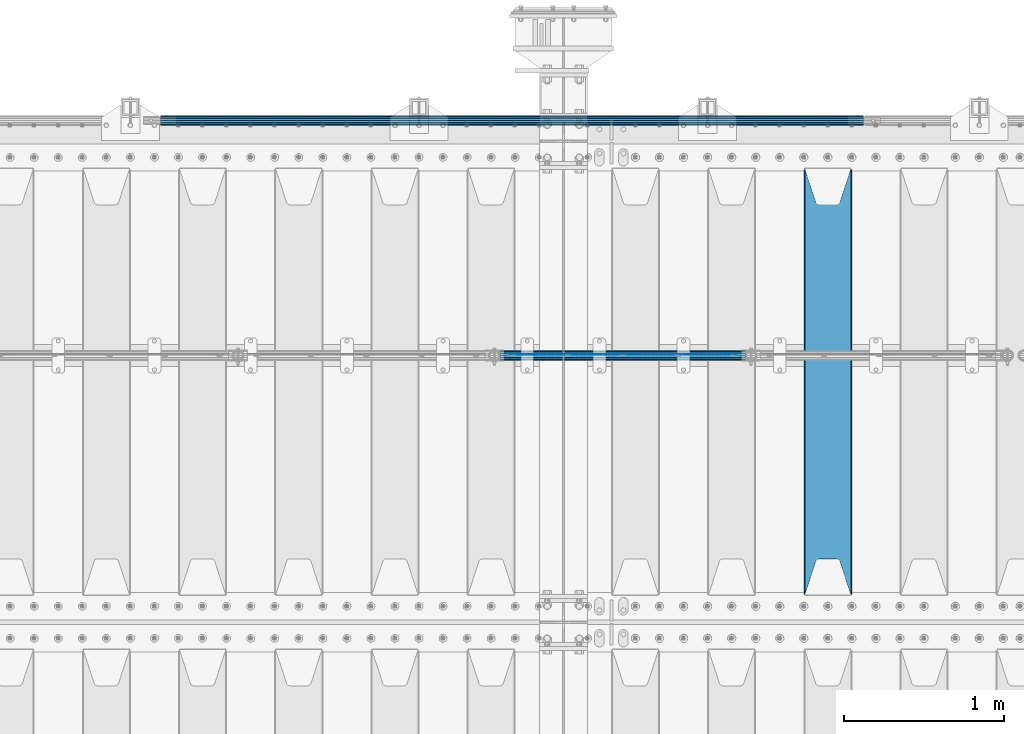
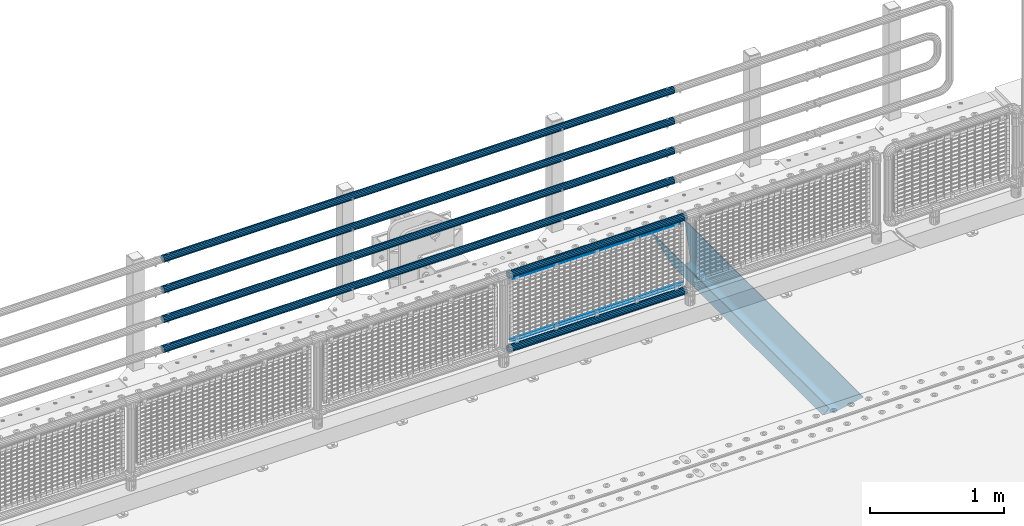
# One storey, part 128 of 247: 10 beams.
"""IFC2X3 building model written with IfcOpenShell, lengths in millimetres."""

from ifc_helpers import new_model, si_unit, frame, origin_with_axes, place, context, subcontext, project, spatial, faceted_brep, material, type_object, element, save


model = new_model("IFC2X3")

# Units and contexts
model_context = context("Model", 3, precision=1e-05, world=origin_with_axes())
body_context = subcontext(model_context, "Body", "Model", "MODEL_VIEW")
ifc_project = project(units=[si_unit("LENGTHUNIT", "METRE", prefix="MILLI"), si_unit("AREAUNIT", "SQUARE_METRE"), si_unit("VOLUMEUNIT", "CUBIC_METRE"), si_unit("MASSUNIT", "GRAM", prefix="KILO"), si_unit("TIMEUNIT", "SECOND"), si_unit("PLANEANGLEUNIT", "RADIAN"), si_unit("SOLIDANGLEUNIT", "STERADIAN"), si_unit("THERMODYNAMICTEMPERATUREUNIT", "DEGREE_CELSIUS"), si_unit("LUMINOUSINTENSITYUNIT", "LUMEN")], contexts=[model_context])

# Site, building, storey
site_placement = place(None, origin_with_axes())
site = spatial("IfcSite", under=ifc_project, at=site_placement, CompositionType="ELEMENT")
building_placement = place(site_placement, origin_with_axes())
building = spatial("IfcBuilding", under=site, at=building_placement, Name="Standard", CompositionType="ELEMENT")
storey_placement = place(building_placement, origin_with_axes())
storey = spatial("IfcBuildingStorey", under=building, at=storey_placement, Name="Undefined", CompositionType="ELEMENT", Elevation=0.0)

# Beams
ifc_material_1 = material(Name="STEEL/S355N")
beam_type_1 = type_object("IfcBeamType", PredefinedType="NOTDEFINED")
beam_1_placement = place(storey_placement, frame((13900.0, 6175.0, -115.0), z_axis=(0.0, 0.0, 1.0), x_axis=(0.0, 1.0, 0.0)))
element("IfcBeam", 1, at=beam_1_placement, inside=storey, type_object=beam_type_1, material=ifc_material_1, context=body_context, shape_type="Brep", body=[
    faceted_brep([(0.0, 150.0, 115.0), (0.0, 143.689999999999, 115.0), (2650.00000000297, 143.689999999999, 115.0), (2650.00000000297, 150.0, 115.0), (2650.00000000297, 142.059565218402, 110.0000000031), (2650.00000000297, 148.369565218403, 110.0000000031), (2441.90079219208, -80.1103600731112, -98.0992078077845), (2437.7588105432, -77.5672621345584, -102.241189456673), (2434.06523489746, -74.4080125315522, -105.934765102404), (2430.91086095089, -70.710272125576, -109.089139048974), (2428.37322971128, -66.5649389910068, -111.626770288588), (2426.51472138054, -62.0739139532889, -113.485278619323), (2425.38102192091, -57.3475956567672, -114.618978078955), (2424.99999999987, -52.5021667386536, -115.0), (2424.99999999987, 52.5021667386536, -115.0), (2425.38102192091, 57.3475956567672, -114.618978078955), (2426.51472138054, 62.0739139532889, -113.485278619323), (2428.37322971128, 66.5649389910068, -111.626770288588), (2430.91086095089, 70.710272125576, -109.089139048974), (2434.06523489746, 74.4080125315522, -105.934765102404), (2437.7588105432, 77.5672621345584, -102.241189456673), (2441.90079219208, 80.1103600731112, -98.0992078077846), (2446.38936140511, 81.9747917625791, -93.6106385947584), (2448.24948500409, 76.2713538057251, -91.7505149957729), (2444.62967112262, 74.76777986261, -95.3703288772456), (2441.28936334126, 72.7168944282894, -98.710636658607), (2438.31067330438, 70.1691124903846, -101.689326695487), (2435.76682334747, 67.1870637758839, -104.233176652398), (2433.72034654133, 63.8440531834895, -106.279653458539), (2432.22154950041, 60.222258798236, -107.778450499454), (2431.30727574265, 56.4107117849089, -108.692724257221), (2430.99999999987, 52.5031078186876, -109.0), (2430.99999999987, -52.5031078186876, -109.0), (2431.30727574265, -56.4107117849089, -108.692724257221), (2432.22154950041, -60.222258798236, -107.778450499454), (2433.72034654133, -63.8440531834895, -106.279653458539), (2435.76682334747, -67.1870637758839, -104.233176652398), (2438.31067330438, -70.1691124903846, -101.689326695487), (2441.28936334126, -72.7168944282894, -98.7106366586071), (2444.62967112262, -74.76777986261, -95.3703288772457), (2448.24948500409, -76.2713538057251, -91.7505149957729), (2650.00000000297, -142.059565218402, 110.0000000031), (2650.00000000297, -148.369565218403, 110.0000000031), (2446.38936140511, -81.9747917625791, -93.6106385947584), (2650.00000000297, -143.689999999999, 115.0), (2650.00000000297, -150.0, 115.0), (0.0, -143.689999999999, 115.0), (0.0, -150.0, 115.0), (0.0, -148.369565218261, 110.000000002663), (203.610638597422, -81.9747917625791, -93.6106385947584), (208.099207810448, -80.1103600731112, -98.0992078077845), (212.241189459336, -77.5672621345584, -102.241189456673), (215.934765105068, -74.4080125315522, -105.934765102404), (219.089139051637, -70.710272125576, -109.089139048974), (221.626770291251, -66.5649389910068, -111.626770288588), (223.485278621985, -62.0739139532889, -113.485278619323), (224.618978081617, -57.3475956567672, -114.618978078955), (225.000000002663, -52.5021667386536, -115.0), (225.000000002663, 52.5021667386536, -115.0), (224.618978081617, 57.3475956567672, -114.618978078955), (223.485278621985, 62.0739139532889, -113.485278619323), (221.626770291251, 66.5649389910068, -111.626770288588), (219.089139051637, 70.710272125576, -109.089139048974), (215.934765105068, 74.4080125315522, -105.934765102404), (212.241189459336, 77.5672621345584, -102.241189456673), (208.099207810448, 80.1103600731112, -98.0992078077846), (203.610638597422, 81.9747917625791, -93.6106385947584), (0.0, 148.369565218261, 110.000000002663), (0.0, 142.05956521826, 110.000000002663), (201.750514998436, 76.2713538057251, -91.7505149957729), (205.370328879908, 74.76777986261, -95.3703288772456), (208.710636661271, 72.7168944282894, -98.710636658607), (211.68932669815, 70.1691124903846, -101.689326695487), (214.233176655061, 67.1870637758839, -104.233176652398), (216.279653461202, 63.8440531834895, -106.279653458539), (217.778450502117, 60.222258798236, -107.778450499454), (218.692724259885, 56.4107117849089, -108.692724257221), (219.000000002663, 52.5031078186876, -109.0), (219.000000002663, -52.5031078186876, -109.0), (218.692724259885, -56.4107117849089, -108.692724257221), (217.778450502117, -60.222258798236, -107.778450499454), (216.279653461202, -63.8440531834895, -106.279653458539), (214.233176655061, -67.1870637758839, -104.233176652398), (211.68932669815, -70.1691124903846, -101.689326695487), (208.710636661271, -72.7168944282894, -98.7106366586071), (205.370328879908, -74.76777986261, -95.3703288772457), (201.750514998436, -76.2713538057251, -91.7505149957729), (0.0, -142.05956521826, 110.000000002663)], [[[0, 1, 2, 3]], [[3, 2, 4, 5]], [[6, 7, 8, 9, 10, 11, 12, 13, 14, 15, 16, 17, 18, 19, 20, 21, 22, 5, 4, 23, 24, 25, 26, 27, 28, 29, 30, 31, 32, 33, 34, 35, 36, 37, 38, 39, 40, 41, 42, 43]], [[44, 45, 42, 41]], [[46, 47, 45, 44]], [[43, 42, 45, 47, 48, 49]], [[6, 43, 49, 50]], [[7, 6, 50, 51]], [[8, 7, 51, 52]], [[9, 8, 52, 53]], [[10, 9, 53, 54]], [[11, 10, 54, 55]], [[12, 11, 55, 56]], [[13, 12, 56, 57]], [[14, 13, 57, 58]], [[15, 14, 58, 59]], [[16, 15, 59, 60]], [[17, 16, 60, 61]], [[18, 17, 61, 62]], [[19, 18, 62, 63]], [[20, 19, 63, 64]], [[21, 20, 64, 65]], [[22, 21, 65, 66]], [[0, 3, 5, 22, 66, 67]], [[1, 0, 67, 68]], [[23, 4, 2, 1, 68, 69]], [[24, 23, 69, 70]], [[25, 24, 70, 71]], [[26, 25, 71, 72]], [[27, 26, 72, 73]], [[28, 27, 73, 74]], [[29, 28, 74, 75]], [[30, 29, 75, 76]], [[31, 30, 76, 77]], [[32, 31, 77, 78]], [[33, 32, 78, 79]], [[34, 33, 79, 80]], [[35, 34, 80, 81]], [[36, 35, 81, 82]], [[37, 36, 82, 83]], [[38, 37, 83, 84]], [[39, 38, 84, 85]], [[40, 39, 85, 86]], [[46, 44, 41, 40, 86, 87]], [[47, 46, 87, 48]], [[86, 85, 84, 83, 82, 81, 80, 79, 78, 77, 76, 75, 74, 73, 72, 71, 70, 69, 68, 67, 66, 65, 64, 63, 62, 61, 60, 59, 58, 57, 56, 55, 54, 53, 52, 51, 50, 49, 48, 87]]]),
])
ifc_material_2 = material()
beam_type_2 = type_object("IfcBeamType", PredefinedType="NOTDEFINED")
beam_2_placement = place(storey_placement, frame((14121.9999999999, 9129.8500000002, 149.849999999725), z_axis=(0.0, 0.0, -1.0), x_axis=(-1.0, 0.0, 0.0)))
element("IfcBeam", 2, at=beam_2_placement, inside=storey, type_object=beam_type_2, material=ifc_material_2, context=body_context, shape_type="Brep", body=[
    faceted_brep([(0.0, -26.5499999999993, 0.0), (0.0, -24.5290015881747, 10.1602451292931), (4384.0, -24.5290015881747, 10.1602451292931), (4384.0, -26.5499999999993, 0.0), (0.0, -18.7736850405036, 18.7736850405028), (4384.0, -18.7736850405036, 18.7736850405028), (0.0, -10.1602451292929, 24.5290015881747), (4384.0, -10.1602451292929, 24.5290015881747), (0.0, 0.0, 26.55), (4384.0, 0.0, 26.55), (0.0, 10.1602451292929, 24.5290015881747), (4384.0, 10.1602451292929, 24.5290015881747), (0.0, 18.7736850405036, 18.7736850405028), (4384.0, 18.7736850405036, 18.7736850405028), (0.0, 24.5290015881747, 10.1602451292931), (4384.0, 24.5290015881747, 10.1602451292931), (0.0, 26.5499999999993, 0.0), (4384.0, 26.5499999999993, 0.0), (0.0, 24.5290015881747, -10.1602451292931), (4384.0, 24.5290015881747, -10.1602451292931), (0.0, 18.7736850405036, -18.7736850405028), (4384.0, 18.7736850405036, -18.7736850405028), (0.0, 10.1602451292929, -24.5290015881747), (4384.0, 10.1602451292929, -24.5290015881747), (0.0, 0.0, -26.55), (4384.0, 0.0, -26.55), (0.0, -10.1602451292929, -24.5290015881747), (4384.0, -10.1602451292929, -24.5290015881747), (0.0, -18.7736850405036, -18.7736850405028), (4384.0, -18.7736850405036, -18.7736850405028), (0.0, -24.5290015881747, -10.1602451292931), (4384.0, -24.5290015881747, -10.1602451292931), (0.0, -30.1499999999996, 0.0), (0.0, -27.8549679052148, -11.5379054858076), (4384.0, -27.8549679052157, -11.5379054858075), (4384.0, -30.1499999999996, 0.0), (0.0, -21.3192694527743, -21.3192694527752), (4384.0, -21.3192694527752, -21.3192694527744), (0.0, -11.5379054858076, -27.8549679052157), (4384.0, -11.5379054858076, -27.8549679052153), (0.0, 0.0, -30.1499999999996), (4384.0, 0.0, -30.15), (0.0, 11.5379054858076, -27.8549679052157), (4384.0, 11.5379054858076, -27.8549679052153), (0.0, 21.3192694527743, -21.3192694527752), (4384.0, 21.3192694527752, -21.3192694527744), (0.0, 27.8549679052157, -11.5379054858076), (4384.0, 27.8549679052157, -11.5379054858074), (0.0, 30.1499999999996, 0.0), (4384.0, 30.1499999999996, 0.0), (0.0, 27.8549679052157, 11.5379054858076), (4384.0, 27.8549679052157, 11.5379054858075), (0.0, 21.3192694527743, 21.3192694527752), (4384.0, 21.3192694527752, 21.3192694527744), (0.0, 11.5379054858076, 27.8549679052157), (4384.0, 11.5379054858076, 27.8549679052153), (0.0, 0.0, 30.1499999999996), (4384.0, 0.0, 30.15), (0.0, -11.5379054858076, 27.8549679052157), (4384.0, -11.5379054858076, 27.8549679052153), (0.0, -21.3192694527743, 21.3192694527752), (4384.0, -21.3192694527752, 21.3192694527744), (0.0, -27.8549679052157, 11.5379054858076), (4384.0, -27.8549679052157, 11.5379054858075)], [[[0, 1, 2, 3]], [[1, 4, 5, 2]], [[4, 6, 7, 5]], [[6, 8, 9, 7]], [[8, 10, 11, 9]], [[10, 12, 13, 11]], [[12, 14, 15, 13]], [[14, 16, 17, 15]], [[16, 18, 19, 17]], [[18, 20, 21, 19]], [[20, 22, 23, 21]], [[22, 24, 25, 23]], [[24, 26, 27, 25]], [[26, 28, 29, 27]], [[28, 30, 31, 29]], [[30, 0, 3, 31]], [[32, 33, 34, 35]], [[33, 36, 37, 34]], [[36, 38, 39, 37]], [[38, 40, 41, 39]], [[40, 42, 43, 41]], [[42, 44, 45, 43]], [[44, 46, 47, 45]], [[46, 48, 49, 47]], [[48, 50, 51, 49]], [[50, 52, 53, 51]], [[52, 54, 55, 53]], [[54, 56, 57, 55]], [[56, 58, 59, 57]], [[58, 60, 61, 59]], [[60, 62, 63, 61]], [[62, 32, 35, 63]], [[37, 39, 41, 43, 45, 47, 49, 51, 53, 55, 57, 59, 61, 63, 35, 34], [5, 7, 9, 11, 13, 15, 17, 19, 21, 23, 25, 27, 29, 31, 3, 2]], [[62, 60, 58, 56, 54, 52, 50, 48, 46, 44, 42, 40, 38, 36, 33, 32], [30, 28, 26, 24, 22, 20, 18, 16, 14, 12, 10, 8, 6, 4, 1, 0]]]),
])
beam_3_placement = place(storey_placement, frame((14121.9999999999, 9129.8500000002, 420.149999999728), z_axis=(0.0, 0.0, -1.0), x_axis=(-1.0, 0.0, 0.0)))
element("IfcBeam", 3, at=beam_3_placement, inside=storey, type_object=beam_type_2, material=ifc_material_2, context=body_context, shape_type="Brep", body=[
    faceted_brep([(0.0, -26.5499999999993, 0.0), (0.0, -24.5290015881747, 10.1602451292931), (4384.0, -24.5290015881747, 10.1602451292931), (4384.0, -26.5499999999993, 0.0), (0.0, -18.7736850405036, 18.7736850405028), (4384.0, -18.7736850405036, 18.7736850405028), (0.0, -10.1602451292929, 24.5290015881747), (4384.0, -10.1602451292929, 24.5290015881747), (0.0, 0.0, 26.55), (4384.0, 0.0, 26.55), (0.0, 10.1602451292929, 24.5290015881747), (4384.0, 10.1602451292929, 24.5290015881747), (0.0, 18.7736850405036, 18.7736850405028), (4384.0, 18.7736850405036, 18.7736850405028), (0.0, 24.5290015881747, 10.1602451292931), (4384.0, 24.5290015881747, 10.1602451292931), (0.0, 26.5499999999993, 0.0), (4384.0, 26.5499999999993, 0.0), (0.0, 24.5290015881747, -10.1602451292931), (4384.0, 24.5290015881747, -10.1602451292931), (0.0, 18.7736850405036, -18.7736850405028), (4384.0, 18.7736850405036, -18.7736850405028), (0.0, 10.1602451292929, -24.5290015881747), (4384.0, 10.1602451292929, -24.5290015881747), (0.0, 0.0, -26.55), (4384.0, 0.0, -26.55), (0.0, -10.1602451292929, -24.5290015881747), (4384.0, -10.1602451292929, -24.5290015881747), (0.0, -18.7736850405036, -18.7736850405028), (4384.0, -18.7736850405036, -18.7736850405028), (0.0, -24.5290015881747, -10.1602451292931), (4384.0, -24.5290015881747, -10.1602451292931), (0.0, -30.1499999999996, 0.0), (0.0, -27.8549679052148, -11.5379054858076), (4384.0, -27.8549679052157, -11.5379054858075), (4384.0, -30.1499999999996, 0.0), (0.0, -21.3192694527743, -21.3192694527752), (4384.0, -21.3192694527752, -21.3192694527744), (0.0, -11.5379054858076, -27.8549679052157), (4384.0, -11.5379054858076, -27.8549679052153), (0.0, 0.0, -30.1499999999996), (4384.0, 0.0, -30.15), (0.0, 11.5379054858076, -27.8549679052157), (4384.0, 11.5379054858076, -27.8549679052153), (0.0, 21.3192694527743, -21.3192694527752), (4384.0, 21.3192694527752, -21.3192694527744), (0.0, 27.8549679052157, -11.5379054858076), (4384.0, 27.8549679052157, -11.5379054858074), (0.0, 30.1499999999996, 0.0), (4384.0, 30.1499999999996, 0.0), (0.0, 27.8549679052157, 11.5379054858076), (4384.0, 27.8549679052157, 11.5379054858075), (0.0, 21.3192694527743, 21.3192694527752), (4384.0, 21.3192694527752, 21.3192694527744), (0.0, 11.5379054858076, 27.8549679052157), (4384.0, 11.5379054858076, 27.8549679052153), (0.0, 0.0, 30.1499999999996), (4384.0, 0.0, 30.15), (0.0, -11.5379054858076, 27.8549679052157), (4384.0, -11.5379054858076, 27.8549679052153), (0.0, -21.3192694527743, 21.3192694527752), (4384.0, -21.3192694527752, 21.3192694527744), (0.0, -27.8549679052157, 11.5379054858076), (4384.0, -27.8549679052157, 11.5379054858075)], [[[0, 1, 2, 3]], [[1, 4, 5, 2]], [[4, 6, 7, 5]], [[6, 8, 9, 7]], [[8, 10, 11, 9]], [[10, 12, 13, 11]], [[12, 14, 15, 13]], [[14, 16, 17, 15]], [[16, 18, 19, 17]], [[18, 20, 21, 19]], [[20, 22, 23, 21]], [[22, 24, 25, 23]], [[24, 26, 27, 25]], [[26, 28, 29, 27]], [[28, 30, 31, 29]], [[30, 0, 3, 31]], [[32, 33, 34, 35]], [[33, 36, 37, 34]], [[36, 38, 39, 37]], [[38, 40, 41, 39]], [[40, 42, 43, 41]], [[42, 44, 45, 43]], [[44, 46, 47, 45]], [[46, 48, 49, 47]], [[48, 50, 51, 49]], [[50, 52, 53, 51]], [[52, 54, 55, 53]], [[54, 56, 57, 55]], [[56, 58, 59, 57]], [[58, 60, 61, 59]], [[60, 62, 63, 61]], [[62, 32, 35, 63]], [[37, 39, 41, 43, 45, 47, 49, 51, 53, 55, 57, 59, 61, 63, 35, 34], [5, 7, 9, 11, 13, 15, 17, 19, 21, 23, 25, 27, 29, 31, 3, 2]], [[62, 60, 58, 56, 54, 52, 50, 48, 46, 44, 42, 40, 38, 36, 33, 32], [30, 28, 26, 24, 22, 20, 18, 16, 14, 12, 10, 8, 6, 4, 1, 0]]]),
])
beam_4_placement = place(storey_placement, frame((14121.9999999999, 9129.8500000002, 969.849999999725), z_axis=(0.0, 0.0, -1.0), x_axis=(-1.0, 0.0, 0.0)))
element("IfcBeam", 4, at=beam_4_placement, inside=storey, type_object=beam_type_2, material=ifc_material_2, context=body_context, shape_type="Brep", body=[
    faceted_brep([(0.0, -26.5499999999993, 0.0), (0.0, -24.5290015881747, 10.1602451292931), (4384.0, -24.5290015881747, 10.1602451292931), (4384.0, -26.5499999999993, 0.0), (0.0, -18.7736850405036, 18.7736850405028), (4384.0, -18.7736850405036, 18.7736850405028), (0.0, -10.1602451292929, 24.5290015881747), (4384.0, -10.1602451292929, 24.5290015881747), (0.0, 0.0, 26.55), (4384.0, 0.0, 26.55), (0.0, 10.1602451292929, 24.5290015881747), (4384.0, 10.1602451292929, 24.5290015881747), (0.0, 18.7736850405036, 18.7736850405028), (4384.0, 18.7736850405036, 18.7736850405028), (0.0, 24.5290015881747, 10.1602451292931), (4384.0, 24.5290015881747, 10.1602451292931), (0.0, 26.5499999999993, 0.0), (4384.0, 26.5499999999993, 0.0), (0.0, 24.5290015881747, -10.1602451292931), (4384.0, 24.5290015881747, -10.1602451292931), (0.0, 18.7736850405036, -18.7736850405028), (4384.0, 18.7736850405036, -18.7736850405028), (0.0, 10.1602451292929, -24.5290015881747), (4384.0, 10.1602451292929, -24.5290015881747), (0.0, 0.0, -26.55), (4384.0, 0.0, -26.55), (0.0, -10.1602451292929, -24.5290015881747), (4384.0, -10.1602451292929, -24.5290015881747), (0.0, -18.7736850405036, -18.7736850405028), (4384.0, -18.7736850405036, -18.7736850405028), (0.0, -24.5290015881747, -10.1602451292931), (4384.0, -24.5290015881747, -10.1602451292931), (0.0, -30.1499999999996, 0.0), (0.0, -27.8549679052148, -11.5379054858076), (4384.0, -27.8549679052157, -11.5379054858075), (4384.0, -30.1499999999996, 0.0), (0.0, -21.3192694527743, -21.3192694527752), (4384.0, -21.3192694527752, -21.3192694527744), (0.0, -11.5379054858076, -27.8549679052157), (4384.0, -11.5379054858076, -27.8549679052153), (0.0, 0.0, -30.1499999999996), (4384.0, 0.0, -30.15), (0.0, 11.5379054858076, -27.8549679052157), (4384.0, 11.5379054858076, -27.8549679052153), (0.0, 21.3192694527743, -21.3192694527752), (4384.0, 21.3192694527752, -21.3192694527744), (0.0, 27.8549679052157, -11.5379054858076), (4384.0, 27.8549679052157, -11.5379054858074), (0.0, 30.1499999999996, 0.0), (4384.0, 30.1499999999996, 0.0), (0.0, 27.8549679052157, 11.5379054858076), (4384.0, 27.8549679052157, 11.5379054858075), (0.0, 21.3192694527743, 21.3192694527752), (4384.0, 21.3192694527752, 21.3192694527744), (0.0, 11.5379054858076, 27.8549679052157), (4384.0, 11.5379054858076, 27.8549679052153), (0.0, 0.0, 30.1499999999996), (4384.0, 0.0, 30.15), (0.0, -11.5379054858076, 27.8549679052157), (4384.0, -11.5379054858076, 27.8549679052153), (0.0, -21.3192694527743, 21.3192694527752), (4384.0, -21.3192694527752, 21.3192694527744), (0.0, -27.8549679052157, 11.5379054858076), (4384.0, -27.8549679052157, 11.5379054858075)], [[[0, 1, 2, 3]], [[1, 4, 5, 2]], [[4, 6, 7, 5]], [[6, 8, 9, 7]], [[8, 10, 11, 9]], [[10, 12, 13, 11]], [[12, 14, 15, 13]], [[14, 16, 17, 15]], [[16, 18, 19, 17]], [[18, 20, 21, 19]], [[20, 22, 23, 21]], [[22, 24, 25, 23]], [[24, 26, 27, 25]], [[26, 28, 29, 27]], [[28, 30, 31, 29]], [[30, 0, 3, 31]], [[32, 33, 34, 35]], [[33, 36, 37, 34]], [[36, 38, 39, 37]], [[38, 40, 41, 39]], [[40, 42, 43, 41]], [[42, 44, 45, 43]], [[44, 46, 47, 45]], [[46, 48, 49, 47]], [[48, 50, 51, 49]], [[50, 52, 53, 51]], [[52, 54, 55, 53]], [[54, 56, 57, 55]], [[56, 58, 59, 57]], [[58, 60, 61, 59]], [[60, 62, 63, 61]], [[62, 32, 35, 63]], [[37, 39, 41, 43, 45, 47, 49, 51, 53, 55, 57, 59, 61, 63, 35, 34], [5, 7, 9, 11, 13, 15, 17, 19, 21, 23, 25, 27, 29, 31, 3, 2]], [[62, 60, 58, 56, 54, 52, 50, 48, 46, 44, 42, 40, 38, 36, 33, 32], [30, 28, 26, 24, 22, 20, 18, 16, 14, 12, 10, 8, 6, 4, 1, 0]]]),
])
beam_5_placement = place(storey_placement, frame((14121.9999999999, 9129.8500000002, 689.849999999725), z_axis=(0.0, 0.0, -1.0), x_axis=(-1.0, 0.0, 0.0)))
element("IfcBeam", 5, at=beam_5_placement, inside=storey, type_object=beam_type_2, material=ifc_material_2, context=body_context, shape_type="Brep", body=[
    faceted_brep([(0.0, -26.5499999999993, 0.0), (0.0, -24.5290015881747, 10.1602451292931), (4384.0, -24.5290015881747, 10.1602451292931), (4384.0, -26.5499999999993, 0.0), (0.0, -18.7736850405036, 18.7736850405028), (4384.0, -18.7736850405036, 18.7736850405028), (0.0, -10.1602451292929, 24.5290015881747), (4384.0, -10.1602451292929, 24.5290015881747), (0.0, 0.0, 26.55), (4384.0, 0.0, 26.55), (0.0, 10.1602451292929, 24.5290015881747), (4384.0, 10.1602451292929, 24.5290015881747), (0.0, 18.7736850405036, 18.7736850405028), (4384.0, 18.7736850405036, 18.7736850405028), (0.0, 24.5290015881747, 10.1602451292931), (4384.0, 24.5290015881747, 10.1602451292931), (0.0, 26.5499999999993, 0.0), (4384.0, 26.5499999999993, 0.0), (0.0, 24.5290015881747, -10.1602451292931), (4384.0, 24.5290015881747, -10.1602451292931), (0.0, 18.7736850405036, -18.7736850405028), (4384.0, 18.7736850405036, -18.7736850405028), (0.0, 10.1602451292929, -24.5290015881747), (4384.0, 10.1602451292929, -24.5290015881747), (0.0, 0.0, -26.55), (4384.0, 0.0, -26.55), (0.0, -10.1602451292929, -24.5290015881747), (4384.0, -10.1602451292929, -24.5290015881747), (0.0, -18.7736850405036, -18.7736850405028), (4384.0, -18.7736850405036, -18.7736850405028), (0.0, -24.5290015881747, -10.1602451292931), (4384.0, -24.5290015881747, -10.1602451292931), (0.0, -30.1499999999996, 0.0), (0.0, -27.8549679052148, -11.5379054858076), (4384.0, -27.8549679052157, -11.5379054858075), (4384.0, -30.1499999999996, 0.0), (0.0, -21.3192694527743, -21.3192694527752), (4384.0, -21.3192694527752, -21.3192694527744), (0.0, -11.5379054858076, -27.8549679052157), (4384.0, -11.5379054858076, -27.8549679052153), (0.0, 0.0, -30.1499999999996), (4384.0, 0.0, -30.15), (0.0, 11.5379054858076, -27.8549679052157), (4384.0, 11.5379054858076, -27.8549679052153), (0.0, 21.3192694527743, -21.3192694527752), (4384.0, 21.3192694527752, -21.3192694527744), (0.0, 27.8549679052157, -11.5379054858076), (4384.0, 27.8549679052157, -11.5379054858074), (0.0, 30.1499999999996, 0.0), (4384.0, 30.1499999999996, 0.0), (0.0, 27.8549679052157, 11.5379054858076), (4384.0, 27.8549679052157, 11.5379054858075), (0.0, 21.3192694527743, 21.3192694527752), (4384.0, 21.3192694527752, 21.3192694527744), (0.0, 11.5379054858076, 27.8549679052157), (4384.0, 11.5379054858076, 27.8549679052153), (0.0, 0.0, 30.1499999999996), (4384.0, 0.0, 30.15), (0.0, -11.5379054858076, 27.8549679052157), (4384.0, -11.5379054858076, 27.8549679052153), (0.0, -21.3192694527743, 21.3192694527752), (4384.0, -21.3192694527752, 21.3192694527744), (0.0, -27.8549679052157, 11.5379054858076), (4384.0, -27.8549679052157, 11.5379054858075)], [[[0, 1, 2, 3]], [[1, 4, 5, 2]], [[4, 6, 7, 5]], [[6, 8, 9, 7]], [[8, 10, 11, 9]], [[10, 12, 13, 11]], [[12, 14, 15, 13]], [[14, 16, 17, 15]], [[16, 18, 19, 17]], [[18, 20, 21, 19]], [[20, 22, 23, 21]], [[22, 24, 25, 23]], [[24, 26, 27, 25]], [[26, 28, 29, 27]], [[28, 30, 31, 29]], [[30, 0, 3, 31]], [[32, 33, 34, 35]], [[33, 36, 37, 34]], [[36, 38, 39, 37]], [[38, 40, 41, 39]], [[40, 42, 43, 41]], [[42, 44, 45, 43]], [[44, 46, 47, 45]], [[46, 48, 49, 47]], [[48, 50, 51, 49]], [[50, 52, 53, 51]], [[52, 54, 55, 53]], [[54, 56, 57, 55]], [[56, 58, 59, 57]], [[58, 60, 61, 59]], [[60, 62, 63, 61]], [[62, 32, 35, 63]], [[37, 39, 41, 43, 45, 47, 49, 51, 53, 55, 57, 59, 61, 63, 35, 34], [5, 7, 9, 11, 13, 15, 17, 19, 21, 23, 25, 27, 29, 31, 3, 2]], [[62, 60, 58, 56, 54, 52, 50, 48, 46, 44, 42, 40, 38, 36, 33, 32], [30, 28, 26, 24, 22, 20, 18, 16, 14, 12, 10, 8, 6, 4, 1, 0]]]),
])
beam_type_3 = type_object("IfcBeamType", PredefinedType="NOTDEFINED")
beam_6_placement = place(storey_placement, frame((11855.85, 7664.50000000001, 298.170000000006), z_axis=(0.0, 0.0, 1.0), x_axis=(1.0, 0.0, 0.0)))
element("IfcBeam", 6, at=beam_6_placement, inside=storey, type_object=beam_type_3, material=ifc_material_2, context=body_context, shape_type="Brep", body=[
    faceted_brep([(0.0, -25.3500000000004, 0.0), (0.0, -23.4203461491616, 9.70102501045585), (1530.0, -23.4203461491616, 9.70102501045506), (1530.0, -25.3500000000004, 0.0), (0.0, -17.9251569030794, 17.9251569030785), (1530.0, -17.9251569030794, 17.925156903079), (0.0, -9.70102501045494, 23.4203461491616), (1530.0, -9.70102501045494, 23.4203461491611), (0.0, 0.0, 25.3500000000004), (1530.0, 0.0, 25.35), (0.0, 9.70102501045494, 23.4203461491616), (1530.0, 9.70102501045494, 23.4203461491611), (0.0, 17.9251569030794, 17.9251569030785), (1530.0, 17.9251569030794, 17.925156903079), (0.0, 23.4203461491616, 9.70102501045585), (1530.0, 23.4203461491616, 9.70102501045506), (0.0, 25.3500000000004, 0.0), (1530.0, 25.3500000000004, 0.0), (0.0, 23.4203461491616, -9.70102501045585), (1530.0, 23.4203461491616, -9.70102501045506), (0.0, 17.9251569030794, -17.9251569030785), (1530.0, 17.9251569030794, -17.925156903079), (0.0, 9.70102501045494, -23.4203461491616), (1530.0, 9.70102501045494, -23.4203461491611), (0.0, 0.0, -25.3500000000004), (1530.0, 0.0, -25.35), (0.0, -9.70102501045494, -23.4203461491616), (1530.0, -9.70102501045494, -23.4203461491611), (0.0, -17.9251569030794, -17.9251569030785), (1530.0, -17.9251569030794, -17.925156903079), (0.0, -23.4203461491616, -9.70102501045585), (1530.0, -23.4203461491616, -9.70102501045506), (0.0, -30.1499999999996, 0.0), (0.0, -27.8549679052148, -11.5379054858076), (1530.0, -27.8549679052148, -11.5379054858075), (1530.0, -30.1499999999996, 0.0), (0.0, -21.3192694527743, -21.3192694527752), (1530.0, -21.3192694527743, -21.3192694527744), (0.0, -11.5379054858076, -27.8549679052157), (1530.0, -11.5379054858076, -27.8549679052153), (0.0, 0.0, -30.1499999999996), (1530.0, 0.0, -30.15), (0.0, 11.5379054858076, -27.8549679052157), (1530.0, 11.5379054858076, -27.8549679052153), (0.0, 21.3192694527743, -21.3192694527752), (1530.0, 21.3192694527743, -21.3192694527744), (0.0, 27.8549679052157, -11.5379054858076), (1530.0, 27.8549679052157, -11.5379054858074), (0.0, 30.1499999999996, 0.0), (1530.0, 30.1499999999996, 0.0), (0.0, 27.8549679052157, 11.5379054858076), (1530.0, 27.8549679052157, 11.5379054858074), (0.0, 21.3192694527743, 21.3192694527752), (1530.0, 21.3192694527743, 21.3192694527744), (0.0, 11.5379054858076, 27.8549679052157), (1530.0, 11.5379054858076, 27.8549679052153), (0.0, 0.0, 30.1499999999996), (1530.0, 0.0, 30.15), (0.0, -11.5379054858076, 27.8549679052157), (1530.0, -11.5379054858076, 27.8549679052153), (0.0, -21.3192694527743, 21.3192694527752), (1530.0, -21.3192694527743, 21.3192694527744), (0.0, -27.8549679052157, 11.5379054858076), (1530.0, -27.8549679052157, 11.5379054858074)], [[[0, 1, 2, 3]], [[1, 4, 5, 2]], [[4, 6, 7, 5]], [[6, 8, 9, 7]], [[8, 10, 11, 9]], [[10, 12, 13, 11]], [[12, 14, 15, 13]], [[14, 16, 17, 15]], [[16, 18, 19, 17]], [[18, 20, 21, 19]], [[20, 22, 23, 21]], [[22, 24, 25, 23]], [[24, 26, 27, 25]], [[26, 28, 29, 27]], [[28, 30, 31, 29]], [[30, 0, 3, 31]], [[32, 33, 34, 35]], [[33, 36, 37, 34]], [[36, 38, 39, 37]], [[38, 40, 41, 39]], [[40, 42, 43, 41]], [[42, 44, 45, 43]], [[44, 46, 47, 45]], [[46, 48, 49, 47]], [[48, 50, 51, 49]], [[50, 52, 53, 51]], [[52, 54, 55, 53]], [[54, 56, 57, 55]], [[56, 58, 59, 57]], [[58, 60, 61, 59]], [[60, 62, 63, 61]], [[62, 32, 35, 63]], [[37, 39, 41, 43, 45, 47, 49, 51, 53, 55, 57, 59, 61, 63, 35, 34], [5, 7, 9, 11, 13, 15, 17, 19, 21, 23, 25, 27, 29, 31, 3, 2]], [[62, 60, 58, 56, 54, 52, 50, 48, 46, 44, 42, 40, 38, 36, 33, 32], [30, 28, 26, 24, 22, 20, 18, 16, 14, 12, 10, 8, 6, 4, 1, 0]]]),
])
beam_7_placement = place(storey_placement, frame((11855.85, 7664.50000000001, 969.850000000005), z_axis=(0.0, 0.0, 1.0), x_axis=(1.0, 0.0, 0.0)))
element("IfcBeam", 7, at=beam_7_placement, inside=storey, type_object=beam_type_3, material=ifc_material_2, context=body_context, shape_type="Brep", body=[
    faceted_brep([(0.0, -25.3500000000004, 0.0), (0.0, -23.4203461491616, 9.70102501045585), (1530.0, -23.4203461491616, 9.70102501045506), (1530.0, -25.3500000000004, 0.0), (0.0, -17.9251569030794, 17.9251569030785), (1530.0, -17.9251569030794, 17.925156903079), (0.0, -9.70102501045494, 23.4203461491616), (1530.0, -9.70102501045494, 23.4203461491611), (0.0, 0.0, 25.3500000000004), (1530.0, 0.0, 25.35), (0.0, 9.70102501045494, 23.4203461491616), (1530.0, 9.70102501045494, 23.4203461491611), (0.0, 17.9251569030794, 17.9251569030785), (1530.0, 17.9251569030794, 17.925156903079), (0.0, 23.4203461491616, 9.70102501045585), (1530.0, 23.4203461491616, 9.70102501045506), (0.0, 25.3500000000004, 0.0), (1530.0, 25.3500000000004, 0.0), (0.0, 23.4203461491616, -9.70102501045585), (1530.0, 23.4203461491616, -9.70102501045506), (0.0, 17.9251569030794, -17.9251569030785), (1530.0, 17.9251569030794, -17.925156903079), (0.0, 9.70102501045494, -23.4203461491616), (1530.0, 9.70102501045494, -23.4203461491611), (0.0, 0.0, -25.3500000000004), (1530.0, 0.0, -25.35), (0.0, -9.70102501045494, -23.4203461491616), (1530.0, -9.70102501045494, -23.4203461491611), (0.0, -17.9251569030794, -17.9251569030785), (1530.0, -17.9251569030794, -17.925156903079), (0.0, -23.4203461491616, -9.70102501045585), (1530.0, -23.4203461491616, -9.70102501045506), (0.0, -30.1499999999996, 0.0), (0.0, -27.8549679052148, -11.5379054858076), (1530.0, -27.8549679052148, -11.5379054858075), (1530.0, -30.1499999999996, 0.0), (0.0, -21.3192694527743, -21.3192694527752), (1530.0, -21.3192694527743, -21.3192694527744), (0.0, -11.5379054858076, -27.8549679052157), (1530.0, -11.5379054858076, -27.8549679052153), (0.0, 0.0, -30.1499999999996), (1530.0, 0.0, -30.15), (0.0, 11.5379054858076, -27.8549679052157), (1530.0, 11.5379054858076, -27.8549679052153), (0.0, 21.3192694527743, -21.3192694527752), (1530.0, 21.3192694527743, -21.3192694527744), (0.0, 27.8549679052157, -11.5379054858076), (1530.0, 27.8549679052157, -11.5379054858074), (0.0, 30.1499999999996, 0.0), (1530.0, 30.1499999999996, 0.0), (0.0, 27.8549679052157, 11.5379054858076), (1530.0, 27.8549679052157, 11.5379054858074), (0.0, 21.3192694527743, 21.3192694527752), (1530.0, 21.3192694527743, 21.3192694527744), (0.0, 11.5379054858076, 27.8549679052157), (1530.0, 11.5379054858076, 27.8549679052153), (0.0, 0.0, 30.1499999999996), (1530.0, 0.0, 30.15), (0.0, -11.5379054858076, 27.8549679052157), (1530.0, -11.5379054858076, 27.8549679052153), (0.0, -21.3192694527743, 21.3192694527752), (1530.0, -21.3192694527743, 21.3192694527744), (0.0, -27.8549679052157, 11.5379054858076), (1530.0, -27.8549679052157, 11.5379054858074)], [[[0, 1, 2, 3]], [[1, 4, 5, 2]], [[4, 6, 7, 5]], [[6, 8, 9, 7]], [[8, 10, 11, 9]], [[10, 12, 13, 11]], [[12, 14, 15, 13]], [[14, 16, 17, 15]], [[16, 18, 19, 17]], [[18, 20, 21, 19]], [[20, 22, 23, 21]], [[22, 24, 25, 23]], [[24, 26, 27, 25]], [[26, 28, 29, 27]], [[28, 30, 31, 29]], [[30, 0, 3, 31]], [[32, 33, 34, 35]], [[33, 36, 37, 34]], [[36, 38, 39, 37]], [[38, 40, 41, 39]], [[40, 42, 43, 41]], [[42, 44, 45, 43]], [[44, 46, 47, 45]], [[46, 48, 49, 47]], [[48, 50, 51, 49]], [[50, 52, 53, 51]], [[52, 54, 55, 53]], [[54, 56, 57, 55]], [[56, 58, 59, 57]], [[58, 60, 61, 59]], [[60, 62, 63, 61]], [[62, 32, 35, 63]], [[37, 39, 41, 43, 45, 47, 49, 51, 53, 55, 57, 59, 61, 63, 35, 34], [5, 7, 9, 11, 13, 15, 17, 19, 21, 23, 25, 27, 29, 31, 3, 2]], [[62, 60, 58, 56, 54, 52, 50, 48, 46, 44, 42, 40, 38, 36, 33, 32], [30, 28, 26, 24, 22, 20, 18, 16, 14, 12, 10, 8, 6, 4, 1, 0]]]),
])
ifc_material_3 = material(Name="Misc_Undefined")
beam_type_4 = type_object("IfcBeamType", Name="D3", PredefinedType="NOTDEFINED")
beam_8_placement = place(storey_placement, frame((11901.0, 7670.50000000001, 353.020000000005), z_axis=(0.0, 0.0, 1.0), x_axis=(1.0, 0.0, 0.0)))
element("IfcBeam", 8, at=beam_8_placement, inside=storey, type_object=beam_type_4, material=ifc_material_3, ObjectType="D3", context=body_context, shape_type="Brep", body=[
    faceted_brep([(1.81898940354586e-12, -1.5, -5.6843418860808e-14), (0.0, -0.75, -1.29903810567703), (1440.0, -0.75, -1.29903810567669), (1440.0, -1.5, 0.0), (0.0, 0.75, -1.29903810567703), (1440.0, 0.75, -1.29903810567663), (1.81898940354586e-12, 1.5, -5.6843418860808e-14), (1440.0, 1.5, 0.0), (0.0, 0.75, 1.29903810567703), (1440.0, 0.75, 1.29903810567669), (0.0, -0.75, 1.29903810567703), (1440.0, -0.75, 1.29903810567669)], [[[0, 1, 2, 3]], [[1, 4, 5, 2]], [[4, 6, 7, 5]], [[6, 8, 9, 7]], [[8, 10, 11, 9]], [[10, 0, 3, 11]], [[5, 7, 9, 11, 3, 2]], [[10, 8, 6, 4, 1, 0]]]),
])
beam_9_placement = place(storey_placement, frame((11876.0, 7670.50000000001, 378.020000000005), z_axis=(0.0, 0.0, 1.0), x_axis=(1.0, 0.0, 0.0)))
element("IfcBeam", 9, at=beam_9_placement, inside=storey, type_object=beam_type_4, material=ifc_material_3, ObjectType="D3", context=body_context, shape_type="Brep", body=[
    faceted_brep([(1.81898940354586e-12, -1.5, -5.6843418860808e-14), (0.0, -0.75, -1.29903810567703), (1490.0, -0.75, -1.29903810567669), (1490.0, -1.5, 0.0), (0.0, 0.75, -1.29903810567703), (1490.0, 0.75, -1.29903810567669), (1.81898940354586e-12, 1.5, -5.6843418860808e-14), (1490.0, 1.5, 0.0), (0.0, 0.75, 1.29903810567703), (1490.0, 0.75, 1.29903810567669), (0.0, -0.75, 1.29903810567703), (1490.0, -0.75, 1.29903810567669)], [[[0, 1, 2, 3]], [[1, 4, 5, 2]], [[4, 6, 7, 5]], [[6, 8, 9, 7]], [[8, 10, 11, 9]], [[10, 0, 3, 11]], [[5, 7, 9, 11, 3, 2]], [[10, 8, 6, 4, 1, 0]]]),
])
beam_10_placement = place(storey_placement, frame((11901.0, 7670.50000000001, 913.020000000005), z_axis=(0.0, 0.0, 1.0), x_axis=(1.0, 0.0, 0.0)))
element("IfcBeam", 10, at=beam_10_placement, inside=storey, type_object=beam_type_4, material=ifc_material_3, ObjectType="D3", context=body_context, shape_type="Brep", body=[
    faceted_brep([(1.81898940354586e-12, -1.5, -5.6843418860808e-14), (0.0, -0.75, -1.29903810567703), (1440.0, -0.75, -1.29903810567669), (1440.0, -1.5, 0.0), (0.0, 0.75, -1.29903810567703), (1440.0, 0.75, -1.29903810567663), (1.81898940354586e-12, 1.5, -5.6843418860808e-14), (1440.0, 1.5, 0.0), (0.0, 0.75, 1.29903810567703), (1440.0, 0.75, 1.29903810567669), (0.0, -0.75, 1.29903810567703), (1440.0, -0.75, 1.29903810567669)], [[[0, 1, 2, 3]], [[1, 4, 5, 2]], [[4, 6, 7, 5]], [[6, 8, 9, 7]], [[8, 10, 11, 9]], [[10, 0, 3, 11]], [[5, 7, 9, 11, 3, 2]], [[10, 8, 6, 4, 1, 0]]]),
])

save(model, "model.ifc")
